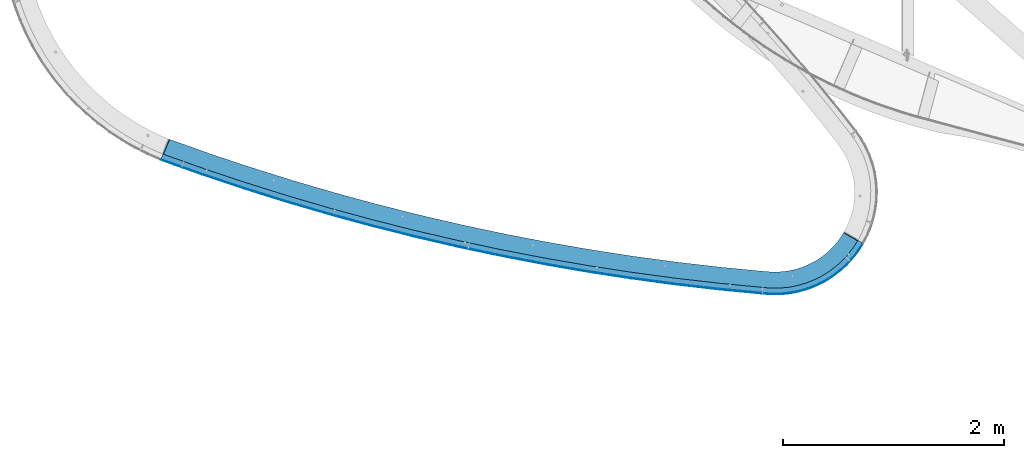
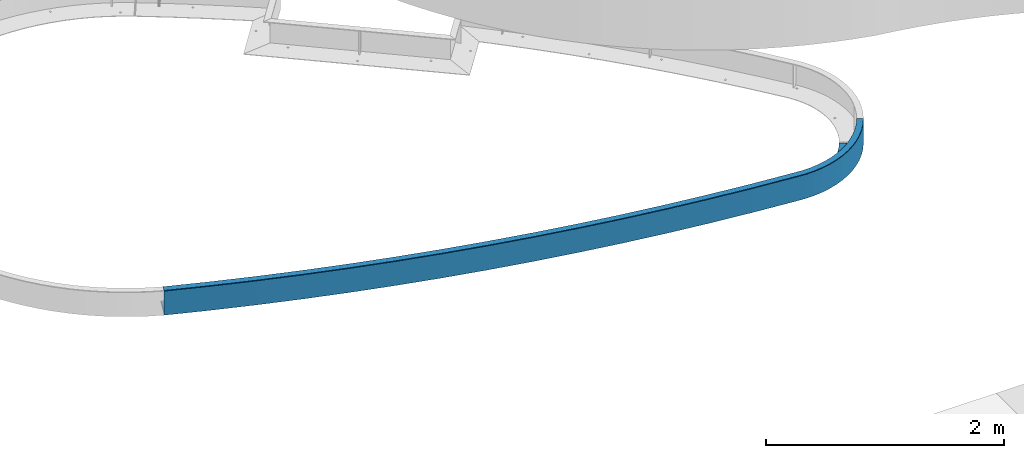
# One storey, part 1137 of 1763: 3 beams, 1 element without a shape of its own.
"""IFC2X3 building model written with IfcOpenShell, lengths in millimetres."""

from ifc_helpers import new_model, si_unit, frame, origin_with_axes, place, context, subcontext, project, spatial, faceted_brep, material, type_object, element, aggregate, save


model = new_model("IFC2X3")

# Units and contexts
model_context = context("Model", 3, precision=1e-05, world=origin_with_axes())
body_context = subcontext(model_context, "Body", "Model", "MODEL_VIEW")
ifc_project = project(units=[si_unit("LENGTHUNIT", "METRE", prefix="MILLI"), si_unit("AREAUNIT", "SQUARE_METRE"), si_unit("VOLUMEUNIT", "CUBIC_METRE"), si_unit("MASSUNIT", "GRAM", prefix="KILO"), si_unit("TIMEUNIT", "SECOND"), si_unit("PLANEANGLEUNIT", "RADIAN"), si_unit("SOLIDANGLEUNIT", "STERADIAN"), si_unit("THERMODYNAMICTEMPERATUREUNIT", "DEGREE_CELSIUS"), si_unit("LUMINOUSINTENSITYUNIT", "LUMEN")], contexts=[model_context])

# Site, building, storey
site_placement = place(None, origin_with_axes())
site = spatial("IfcSite", under=ifc_project, at=site_placement, CompositionType="ELEMENT")
building_placement = place(site_placement, origin_with_axes())
building = spatial("IfcBuilding", under=site, at=building_placement, Name="Undefined", CompositionType="ELEMENT")
storey_placement = place(building_placement, origin_with_axes())
storey = spatial("IfcBuildingStorey", under=building, at=storey_placement, Name="Undefined", CompositionType="ELEMENT", Elevation=0.0)

# Assembly, beams
assembly_placement = place(storey_placement, origin_with_axes())
assembly = element("IfcElementAssembly", 1, at=assembly_placement, inside=storey, Name="PLATE", AssemblyPlace="NOTDEFINED", PredefinedType="RIGID_FRAME")
ifc_material = material(Name="STEEL/A36")
beam_type_1 = type_object("IfcBeamType", PredefinedType="NOTDEFINED")
beam_1_placement = place(assembly_placement, frame((-53076.8570510666, 58481.2077564262, -250.825), z_axis=(0.27606807308732, 0.961138085304008, 0.0), x_axis=(0.961138085304008, -0.276068073087321, 0.0)))
beam_1 = element("IfcBeam", 2, at=beam_1_placement, type_object=beam_type_1, material=ifc_material, Name="PLATE", context=body_context, shape_type="Brep", body=[
    faceted_brep([(6318.82231450954, -1.11174358607968e-07, 927.30162043187), (6127.52354438154, -9.04748560515145e-08, 974.563433684867), (6125.72221636436, -3.17500000000001, 968.467541585356), (6317.02098650363, -3.17500000000001, 921.205728348854), (6094.23574031491, 3.17500000000001, 875.030074772294), (6094.23574031491, -3.17500000000001, 875.030074772294), (6112.92813320937, -3.17500000000001, 925.170957242546), (6112.92813320937, 3.17500000000001, 925.170957242546), (6072.11168569588, 3.17500000000001, 826.322101653786), (6072.11168569588, -3.17500000000001, 826.322101653786), (6046.65377505225, 3.17500000000001, 779.262257808557), (6046.65377505225, -3.17500000000001, 779.262257808557), (6018.67771271574, 3.17500000000001, 735.170138887748), (6018.67771271574, -3.17500000000001, 735.170138887748), (5987.58342440233, 3.17500000000001, 694.117283486135), (5987.58342440233, -3.17500000000001, 694.117283486135), (5952.56895111006, 3.17500000000001, 654.606839056389), (5952.56895111006, -3.17500000000001, 654.606839056389), (5914.38961194663, 3.17500000000001, 617.128491528601), (5914.38961194663, -3.17500000000001, 617.128491528601), (5873.69960085145, 3.17500000000001, 582.393143930181), (5873.69960085145, -3.17500000000001, 582.393143930181), (5831.14920615496, 3.17500000000001, 550.904240759119), (5831.14920615496, -3.17500000000001, 550.904240759119), (5787.56044065311, 3.17500000000001, 523.476084588234), (5787.56044065311, -3.17500000000001, 523.476084588234), (5741.30508837246, 3.17500000000001, 499.550699930085), (5741.30508837246, -3.17500000000001, 499.550699930085), (5692.1878851678, 3.17500000000001, 478.329351628185), (5692.1878851678, -3.17500000000001, 478.329351628185), (5641.72279028408, 3.17500000000001, 460.573819615332), (5641.72279028408, -3.17500000000001, 460.573819615332), (5590.06474646219, 3.17500000000001, 446.344274861054), (5590.06474646219, -3.17500000000001, 446.344274861054), (5532.32007577916, 3.17500000000001, 434.638579659295), (5532.32007577916, -3.17500000000001, 434.638579659295), (5531.83051360548, 3.17500000000001, 434.536833708546), (5531.83051360548, -3.17500000000001, 434.536833708546), (5142.47181492758, -3.17500000000001, 362.271568563781), (5142.47181492758, 3.17500000000001, 362.271568563781), (4751.81957522286, -3.17500000000001, 297.36168952928), (4751.81957522286, 3.17500000000001, 297.36168952928), (4360.01273256006, -3.17500000000001, 239.830282235482), (4360.01273256006, 3.17500000000001, 239.830282235482), (3967.19063565018, -3.17500000000001, 189.697808110235), (3967.19063565018, 3.17500000000001, 189.697808110235), (3573.49299428613, -3.17500000000001, 146.982097101609), (3573.49299428613, 3.17500000000001, 146.982097101609), (3179.05982965402, -3.17500000000001, 111.698341336472), (3179.05982965402, 3.17500000000001, 111.698341336472), (2784.03142453372, -3.17500000000001, 83.8590897173781), (2784.03142453372, 3.17500000000001, 83.8590897173781), (2388.54827340636, -3.17500000000001, 63.4742434594227), (2388.54827340636, 3.17500000000001, 63.4742434594227), (1992.75103248647, -3.17500000000001, 50.5510525688296), (1992.75103248647, 3.17500000000001, 50.5510525688296), (1596.78046969674, -3.17500000000001, 45.0941132644512), (1596.78046969674, 3.17500000000001, 45.0941132644512), (1200.7774146029, -3.17500000000001, 47.1053663430575), (1200.7774146029, 3.17500000000001, 47.1053663430575), (804.882708326841, -3.17500000000001, 56.5840964891177), (804.882708326841, 3.17500000000001, 56.5840964891177), (409.237153455426, -3.17500000000001, 73.5269325291592), (409.237153455426, 3.17500000000001, 73.5269325291592), (20.5117208271404, 3.17500000000001, 97.5247064266587), (20.5117208271404, 5.42727889296657e-08, 97.5247064266587), (26.855421667904, -3.17499997547534, 97.1330811670996), (6276.29428328179, -3.17500000000001, 799.853851910615), (6276.29428328179, 3.17500000000001, 799.853851910615), (6299.76876525953, 3.17500000000001, 862.82231445791), (6299.76876525953, -3.17500000000001, 862.82231445791), (6248.50823135956, -3.17500000000001, 738.680513957494), (6248.50823135956, 3.17500000000001, 738.680513957494), (6216.53629747939, -3.17500000000001, 679.57926889103), (6216.53629747939, 3.17500000000001, 679.57926889103), (6180.52264163674, -3.17500000000001, 622.819372623933), (6180.52264163674, 3.17500000000001, 622.819372623933), (6139.92997826181, -3.17500000000001, 569.226097772218), (6139.92997826181, 3.17500000000001, 569.226097772218), (6095.35232776908, -3.17500000000001, 518.924533390506), (6095.35232776908, 3.17500000000001, 518.924533390506), (6047.40306693633, -3.17500000000001, 471.855644809155), (6047.40306693633, 3.17500000000001, 471.855644809155), (5996.30064932723, -3.17500000000001, 428.231664598963), (5996.30064932723, 3.17500000000001, 428.231664598963), (5942.27602248493, -3.17500000000001, 388.251395188352), (5942.27602248493, 3.17500000000001, 388.251395188352), (5885.37250905599, -3.17500000000001, 352.444956647829), (5885.37250905599, 3.17500000000001, 352.444956647829), (5825.66324080095, -3.17500000000001, 321.560591050751), (5825.66324080095, 3.17500000000001, 321.560591050751), (5763.97857865328, -3.17500000000001, 294.909405418992), (5763.97857865328, 3.17500000000001, 294.909405418992), (5700.59891293702, -3.17500000000001, 272.610038179468), (5700.59891293702, 3.17500000000001, 272.610038179468), (5635.81159982171, -3.17500000000001, 254.76395065312), (5635.81159982171, 3.17500000000001, 254.76395065312), (5571.42900308751, -3.17500000000001, 241.712650078473), (5571.42900308751, 3.17500000000001, 241.712650078473), (5569.5759632992, -3.17500000000001, 241.339516110056), (5569.57596329931, 3.17500000000001, 241.339516110078), (5176.56723295026, 3.17500000000001, 168.396802362266), (5176.56723295026, -3.17500000000001, 168.396802362266), (4782.25283531217, 3.17500000000001, 102.878427575532), (4782.25283531217, -3.17500000000001, 102.878427575532), (4386.77301092455, 3.17500000000001, 44.807693795854), (4386.77301092455, -3.17500000000001, 44.807693795854), (3990.26841481875, 3.17500000000001, -5.79474573384505), (3990.26841481875, -3.17500000000001, -5.79474573384505), (3592.88006649304, 3.17500000000001, -48.910893919201), (3592.88006649304, -3.17500000000001, -48.910893919201), (3194.74929975803, 3.17500000000001, -84.5254162151759), (3194.74929975803, -3.17500000000001, -84.5254162151759), (2796.01771247038, 3.17500000000001, -112.625646079912), (2796.01771247038, -3.17500000000001, -112.625646079912), (2396.82711617259, 3.17500000000001, -133.201589479671), (2396.82711617259, -3.17500000000001, -133.201589479671), (1997.31948565675, 3.17500000000001, -146.245928443233), (1997.31948565675, -3.17500000000001, -146.245928443233), (1597.63690847029, 3.17500000000001, -151.754023664646), (1597.63690847029, -3.17500000000001, -151.754023664646), (1197.92153438159, 3.17500000000001, -149.723916153212), (1197.92153438159, -3.17500000000001, -149.723916153212), (798.315524823454, 3.17500000000001, -140.156327930134), (798.315524823454, -3.17500000000001, -140.156327930134), (398.961002332493, 3.17500000000001, -123.054661771865), (398.961002332493, -3.17500000000001, -123.054661771865), (5.59484760742635e-08, 3.17500000000001, -98.4250000019238), (6.34370078513166, -3.17500000000001, -98.8166252557639), (5.59484760742635e-08, 2.91902608751116e-08, -98.4250000019238), (6127.52354438154, 3.17500000000001, 974.563433684867), (6318.82231447691, 3.17500000000001, 927.301620299797)], [[[0, 1, 2, 3]], [[4, 5, 6, 7]], [[8, 9, 5, 4]], [[10, 11, 9, 8]], [[12, 13, 11, 10]], [[14, 15, 13, 12]], [[16, 17, 15, 14]], [[18, 19, 17, 16]], [[20, 21, 19, 18]], [[22, 23, 21, 20]], [[24, 25, 23, 22]], [[26, 27, 25, 24]], [[28, 29, 27, 26]], [[30, 31, 29, 28]], [[32, 33, 31, 30]], [[34, 35, 33, 32]], [[36, 37, 35, 34]], [[38, 37, 36, 39]], [[40, 38, 39, 41]], [[42, 40, 41, 43]], [[44, 42, 43, 45]], [[46, 44, 45, 47]], [[48, 46, 47, 49]], [[50, 48, 49, 51]], [[52, 50, 51, 53]], [[54, 52, 53, 55]], [[56, 54, 55, 57]], [[58, 56, 57, 59]], [[60, 58, 59, 61]], [[62, 60, 61, 63]], [[62, 63, 64, 65, 66]], [[67, 68, 69, 70]], [[71, 72, 68, 67]], [[73, 74, 72, 71]], [[75, 76, 74, 73]], [[77, 78, 76, 75]], [[79, 80, 78, 77]], [[81, 82, 80, 79]], [[83, 84, 82, 81]], [[85, 86, 84, 83]], [[87, 88, 86, 85]], [[89, 90, 88, 87]], [[91, 92, 90, 89]], [[93, 94, 92, 91]], [[95, 96, 94, 93]], [[97, 98, 96, 95]], [[99, 100, 98, 97]], [[101, 100, 99, 102]], [[103, 101, 102, 104]], [[105, 103, 104, 106]], [[107, 105, 106, 108]], [[109, 107, 108, 110]], [[111, 109, 110, 112]], [[113, 111, 112, 114]], [[115, 113, 114, 116]], [[117, 115, 116, 118]], [[119, 117, 118, 120]], [[121, 119, 120, 122]], [[123, 121, 122, 124]], [[125, 123, 124, 126]], [[127, 125, 126, 128, 129]], [[66, 65, 129, 128]], [[64, 127, 129, 65]], [[63, 61, 59, 57, 55, 53, 51, 49, 47, 45, 43, 41, 39, 36, 34, 32, 30, 28, 26, 24, 22, 20, 18, 16, 14, 12, 10, 8, 4, 7, 130, 131, 69, 68, 72, 74, 76, 78, 80, 82, 84, 86, 88, 90, 92, 94, 96, 98, 100, 101, 103, 105, 107, 109, 111, 113, 115, 117, 119, 121, 123, 125, 127, 64]], [[70, 69, 131, 0, 3]], [[6, 5, 9, 11, 13, 15, 17, 19, 21, 23, 25, 27, 29, 31, 33, 35, 37, 38, 40, 42, 44, 46, 48, 50, 52, 54, 56, 58, 60, 62, 66, 128, 126, 124, 122, 120, 118, 116, 114, 112, 110, 108, 106, 104, 102, 99, 97, 95, 93, 91, 89, 87, 85, 83, 81, 79, 77, 75, 73, 71, 67, 70, 3, 2]], [[130, 7, 6, 2, 1]], [[131, 130, 1, 0]]]),
])
beam_type_2 = type_object("IfcBeamType", PredefinedType="NOTDEFINED")
beam_2_placement = place(assembly_placement, frame((-46744.2698418956, 57627.1933740728, -130.175), z_axis=(0.0, 0.0, 1.0), x_axis=(-0.728032501654395, -0.685542614674568, 0.0)))
beam_2 = element("IfcBeam", 3, at=beam_2_placement, type_object=beam_type_2, material=ifc_material, Name="PLATE", context=body_context, shape_type="Brep", body=[
    faceted_brep([(7.99235992491413, -1.3421208866057, 123.825), (0.918660438013831, 0.135807899350766, 123.825), (0.918660438013831, 0.135807899350766, -123.825), (7.99234691937272, -1.34206961603195, -123.825), (-9.89530235528946e-10, 3.17499999998108, -123.825), (-9.89530235528946e-10, 3.17499999998108, 123.825), (80.6977583252865, 23.6451929419563, 123.825), (80.6977583252865, 23.6451929419563, -123.825), (162.911739607442, 36.760766880092, 123.825), (162.911739607442, 36.760766880092, -123.825), (245.973081028895, 42.415018312342, 123.825), (245.973081028895, 42.415018312342, -123.825), (329.20602596169, 40.561946321599, 123.825), (329.20602596169, 40.561946321599, -123.825), (411.933421674634, 31.2166268223373, 123.825), (411.933421674634, 31.2166268223373, -123.825), (493.48222839966, 14.4550899085298, 123.825), (493.48222839966, 14.4550899085298, -123.825), (573.188994936701, -9.58629869940341, 123.825), (573.188994936701, -9.58629869940341, -123.825), (650.405256249474, -40.7119470760517, 123.825), (650.405256249474, -40.7119470760517, -123.825), (724.502809139316, -78.6686283551971, 123.825), (724.502809139316, -78.6686283551971, -123.825), (794.878823076118, -123.147540890859, 123.825), (794.878823076118, -123.147540890859, -123.825), (860.960744606591, -173.786820554262, 123.825), (860.960744606591, -173.786820554262, -123.825), (922.210955439294, -230.17448472773, 123.825), (922.210955439294, -230.17448472773, -123.825), (978.131146309939, -291.851784044236, 123.825), (978.131146309939, -291.851784044236, -123.825), (978.777592559496, -292.632858783894, 123.825), (978.777592559496, -292.632858783894, -123.825), (979.434201557646, -293.368561150884, 123.825), (979.434201557646, -293.368561150884, -123.825), (1242.81164874635, -594.132378442766, 123.825), (1242.81164874635, -594.132378442766, -123.825), (1500.47124140349, -899.808821420273, 123.825), (1500.47124140349, -899.808821420273, -123.825), (1752.32136637089, -1210.28920410736, 123.825), (1752.32136637089, -1210.28920410736, -123.825), (1998.27247609828, -1525.46313244454, 123.825), (1998.27247609828, -1525.46313244454, -123.825), (2238.23712048266, -1845.21854354042, 123.825), (2238.23712048266, -1845.21854354042, -123.825), (2472.12997796201, -2169.44174551673, 123.825), (2472.12997796201, -2169.44174551673, -123.825), (2699.86788585211, -2498.01745793241, 123.825), (2699.86788585211, -2498.01745793241, -123.825), (2921.36986991572, -2830.82885277265, 123.825), (2921.36986991572, -2830.82885277265, -123.825), (3136.55717315379, -3167.75759598808, 123.825), (3136.55717315379, -3167.75759598808, -123.825), (3345.35328380816, -3508.6838895696, 123.825), (3345.35328380816, -3508.6838895696, -123.825), (3547.68396256597, -3853.48651414347, 123.825), (3547.68396256597, -3853.48651414347, -123.825), (3743.47726895613, -4202.04287207202, 123.825), (3743.47726895613, -4202.04287207202, -123.825), (3932.66358692843, -4554.22903104439, 123.825), (3932.66358692843, -4554.22903104439, -123.825), (4115.17564960615, -4909.9197681417, 123.825), (4115.17564960615, -4909.9197681417, -123.825), (4112.3238753683, -4911.31593058459, 123.825), (4112.33723008117, -4911.34257253062, -123.825), (4106.60006284934, -4907.11586190463, 123.825), (4106.60006284934, -4907.11586190463, -123.825), (3927.04151622048, -4557.18111860318, 123.825), (3927.04151622048, -4557.18111860318, -123.825), (3737.91186062035, -4205.10044137725, -123.825), (3737.91186062035, -4205.10044137725, 123.825), (3542.17719543277, -3856.64847804914, -123.825), (3542.17719543277, -3856.64847804914, 123.825), (3339.90711585753, -3511.94912381138, -123.825), (3339.90711585753, -3511.94912381138, 123.825), (3131.17354081916, -3171.12493958292, -123.825), (3131.17354081916, -3171.12493958292, 123.825), (2916.0506873954, -2834.29710843158, -123.825), (2916.0506873954, -2834.29710843158, 123.825), (2694.61504442872, -2501.5853924863, -123.825), (2694.61504442872, -2501.5853924863, 123.825), (2466.94534533004, -2173.10809035478, -123.825), (2466.94534533004, -2173.10809035478, 123.825), (2233.12254008428, -1848.98199506113, -123.825), (2233.12254008428, -1848.98199506113, 123.825), (1993.22976646801, -1529.32235251924, -123.825), (1993.22976646801, -1529.32235251924, 123.825), (1747.35232048897, -1214.24282055609, -123.825), (1747.35232048897, -1214.24282055609, 123.825), (1495.57762605834, -903.855428499548, -123.825), (1495.57762605834, -903.855428499548, 123.825), (1237.99520390641, -598.270537345452, -123.825), (1237.99520390641, -598.270537345452, 123.825), (974.696639752668, -297.596800517829, 123.825), (974.696639752668, -297.596800517829, -123.825), (973.961196847746, -296.772768121911, 123.825), (973.961196847746, -296.772768121911, -123.825), (973.239264095804, -295.900486108265, 123.825), (973.239264095804, -295.900486108265, -123.825), (917.703784743198, -234.647505219124, -123.825), (917.703784743198, -234.647505219124, 123.825), (856.874954117242, -178.647768617884, -123.825), (856.874954117242, -178.647768617884, 123.825), (791.247653287281, -128.356869635027, -123.825), (791.247653287281, -128.356869635027, 123.825), (721.355801917407, -84.1839565906994, -123.825), (721.355801917407, -84.1839565906994, 123.825), (647.768014491738, -46.4884041140031, -123.825), (647.768014491738, -46.4884041140031, 123.825), (571.08297427539, -15.5768894026842, -123.825), (571.08297427539, -15.5768894026842, 123.825), (491.924562646918, 8.29910279004253, -123.825), (491.924562646918, 8.29910279004253, 123.825), (410.936783428077, 24.9453261434101, -123.825), (410.936783428077, 24.9453261434101, 123.825), (328.778523504776, 34.2263530858036, -123.825), (328.778523504776, 34.2263530858036, 123.825), (246.118192364911, 36.066676583956, -123.825), (246.118192364911, 36.066676583956, 123.825), (163.628284163757, 30.4513244404516, -123.825), (163.628284163757, 30.4513244404516, 123.825), (81.9799065580428, 17.4259811020602, -123.825), (81.9799065580428, 17.4259811020602, 123.825)], [[[0, 1, 2, 3]], [[4, 5, 6, 7]], [[6, 8, 9, 7]], [[8, 10, 11, 9]], [[10, 12, 13, 11]], [[12, 14, 15, 13]], [[14, 16, 17, 15]], [[16, 18, 19, 17]], [[18, 20, 21, 19]], [[20, 22, 23, 21]], [[22, 24, 25, 23]], [[24, 26, 27, 25]], [[26, 28, 29, 27]], [[28, 30, 31, 29]], [[31, 30, 32, 33]], [[33, 32, 34, 35]], [[35, 34, 36, 37]], [[36, 38, 39, 37]], [[38, 40, 41, 39]], [[40, 42, 43, 41]], [[42, 44, 45, 43]], [[44, 46, 47, 45]], [[46, 48, 49, 47]], [[48, 50, 51, 49]], [[50, 52, 53, 51]], [[52, 54, 55, 53]], [[54, 56, 57, 55]], [[56, 58, 59, 57]], [[58, 60, 61, 59]], [[60, 62, 63, 61]], [[63, 62, 64, 65]], [[64, 66, 67, 65]], [[68, 69, 67, 66]], [[70, 69, 68, 71]], [[72, 70, 71, 73]], [[74, 72, 73, 75]], [[76, 74, 75, 77]], [[78, 76, 77, 79]], [[80, 78, 79, 81]], [[82, 80, 81, 83]], [[84, 82, 83, 85]], [[86, 84, 85, 87]], [[88, 86, 87, 89]], [[90, 88, 89, 91]], [[92, 90, 91, 93]], [[94, 95, 92, 93]], [[96, 97, 95, 94]], [[98, 99, 97, 96]], [[100, 99, 98, 101]], [[102, 100, 101, 103]], [[104, 102, 103, 105]], [[106, 104, 105, 107]], [[108, 106, 107, 109]], [[110, 108, 109, 111]], [[112, 110, 111, 113]], [[114, 112, 113, 115]], [[116, 114, 115, 117]], [[118, 116, 117, 119]], [[120, 118, 119, 121]], [[122, 120, 121, 123]], [[122, 123, 0, 3]], [[4, 7, 9, 11, 13, 15, 17, 19, 21, 23, 25, 27, 29, 31, 33, 35, 37, 39, 41, 43, 45, 47, 49, 51, 53, 55, 57, 59, 61, 63, 65, 67, 69, 70, 72, 74, 76, 78, 80, 82, 84, 86, 88, 90, 92, 95, 97, 99, 100, 102, 104, 106, 108, 110, 112, 114, 116, 118, 120, 122, 3, 2]], [[5, 4, 2, 1]], [[123, 121, 119, 117, 115, 113, 111, 109, 107, 105, 103, 101, 98, 96, 94, 93, 91, 89, 87, 85, 83, 81, 79, 77, 75, 73, 71, 68, 66, 64, 62, 60, 58, 56, 54, 52, 50, 48, 46, 44, 42, 40, 38, 36, 34, 32, 30, 28, 26, 24, 22, 20, 18, 16, 14, 12, 10, 8, 6, 5, 1, 0]]]),
])
beam_type_3 = type_object("IfcBeamType", PredefinedType="NOTDEFINED")
beam_3_placement = place(assembly_placement, frame((-46761.6823899913, 57645.6854091817, -3.17499999999491), z_axis=(0.685542614674568, -0.728032501654395, 0.0), x_axis=(-0.728032501654395, -0.685542614674568, 0.0)))
beam_3 = element("IfcBeam", 4, at=beam_3_placement, type_object=beam_type_3, material=ifc_material, Name="PLATE", context=body_context, shape_type="Brep", body=[
    faceted_brep([(22.690981146161, 3.17500000464634, -24.5689123684278), (16.5358801446364, 9.96558560117933e-08, -26.1304583013844), (-8.84756445884705e-09, 9.69761293490023e-09, 28.5749999999134), (6.15508562162904, 3.175, 30.1365420300572), (80.6389212364975, -3.175, 49.0330525091995), (162.792356629785, -3.175, 62.1471892756817), (162.792356629785, 3.175, 62.1471892756817), (80.6389212364975, 3.175, 49.0330525091995), (245.792900142887, -3.175, 67.810872404094), (245.792900142887, 3.175, 67.810872404094), (328.966263915996, -3.175, 65.9780907165405), (328.966263915996, 3.175, 65.9780907165405), (411.636756115355, -3.175, 56.6637335424894), (411.636756115355, 3.175, 56.6637335424894), (493.132770184007, -3.175, 39.9434697595425), (493.132770184007, 3.175, 39.9434697595425), (572.792240904275, -3.175, 15.9531330671016), (572.792240904275, 3.175, 15.9531330671016), (649.968022947332, -3.175, -15.1123815124447), (649.968022947332, 3.175, -15.1123815124447), (724.03314821514, -3.175, -53.0007009408873), (724.03314821514, 3.175, -53.0007009408873), (794.385919264672, -3.175, -97.4040244167263), (794.385919264672, 3.175, -97.4040244167263), (860.454797435903, -3.175, -147.961623917159), (860.454797435903, 3.175, -147.961623917159), (921.703045972938, -3.175, -204.262774715287), (921.703045972938, 3.175, -204.262774715287), (977.63309041814, -3.175, -265.850092065593), (977.63309041814, 3.175, -265.850092065593), (978.280399047517, -3.175, -266.630861772472), (978.280399047517, 3.175, -266.630861772472), (978.936813269424, -3.175, -267.3663157837), (978.936813269424, 3.175, -267.3663157837), (1242.35699351795, -3.175, -568.166885436833), (1242.35699351795, 3.175, -568.166885436833), (1500.05831639211, -3.175, -873.881134785333), (1500.05831639211, 3.175, -873.881134785333), (1751.94914428746, -3.175, -1184.40035301185), (1751.94914428746, 3.175, -1184.40035301185), (1997.93990578937, -3.175, -1499.61412067042), (1997.93990578937, 3.175, -1499.61412067042), (2237.94312752423, -3.175, -1819.41034895134), (2237.94312752423, 3.175, -1819.41034895134), (2471.87346526465, -3.175, -2143.67531953937), (2471.87346526465, 3.175, -2143.67531953937), (2699.64773427759, -3.175, -2472.29372505163), (2699.64773427759, 3.175, -2472.29372505163), (2921.18493890447, -3.175, -2805.14871004048), (2921.18493890447, 3.175, -2805.14871004048), (3136.40630136292, -3.175, -3142.12191254675), (3136.40630136292, 3.175, -3142.12191254675), (3345.23528975993, -3.175, -3483.09350618892), (3345.23528975993, 3.175, -3483.09350618892), (3547.59764530622, -3.175, -3827.9422427729), (3547.59764530622, 3.175, -3827.9422427729), (3743.4214087224, -3.175, -4176.54549540736), (3743.4214087224, 3.175, -4176.54549540736), (3932.63694582744, -3.175, -4528.77930210947), (3932.63694582744, 3.175, -4528.77930210947), (4115.17697230037, -3.175, -4884.51840988529), (4115.17680408879, 4.01432575181104e-07, -4884.51804551187), (4112.37157467348, 3.175, -4879.05117254547), (169.248649110321, 3.175, 5.3630472341174), (247.110061576148, 3.175, 10.6760530226748), (247.110061576148, -3.175, 10.6760530226748), (169.248649110321, -3.175, 5.3630472341174), (325.133593818284, 3.175, 8.95675137842773), (325.133593818284, -3.175, 8.95675137842773), (402.685390703447, 3.175, 0.219109730722266), (402.685390703447, -3.175, 0.219109730722266), (479.135429427815, 3.175, -15.4658882203803), (479.135429427815, -3.175, -15.4658882203803), (553.862637757267, 3.175, -37.9708191683021), (553.862637757267, -3.175, -37.9708191683021), (626.259939554193, 3.175, -67.1128553738818), (626.259939554193, -3.175, -67.1128553738818), (695.73918660154, 3.175, -102.655249938922), (695.73918660154, -3.175, -102.655249938922), (761.735936658219, 3.175, -144.309260113689), (761.735936658219, -3.175, -144.309260113689), (823.714038929707, 3.175, -191.736493013246), (823.714038929707, -3.175, -191.736493013246), (881.169989701872, 3.175, -244.551654686278), (881.169989701872, -3.175, -244.551654686278), (933.637022753204, 3.175, -302.325680203576), (933.637022753204, -3.175, -302.325680203576), (934.949326651304, 3.175, -303.908552860201), (934.949326651304, -3.175, -303.908552860201), (936.299531176957, 3.175, -305.421337472799), (936.299531176965, -3.175, -305.421337472799), (1199.00971079419, 3.175, -605.411154532296), (1199.00971079419, -3.175, -605.411154532296), (1456.01644716491, 3.175, -910.301407367588), (1456.01644716491, -3.175, -910.301407367588), (1707.22834967704, 3.175, -1219.98367817129), (1707.22834967704, -3.175, -1219.98367817129), (1952.55608833918, 3.175, -1534.34784511279), (1952.55608833918, -3.175, -1534.34784511279), (2191.9124255461, 3.175, -1853.28212149709), (2191.9124255461, -3.175, -1853.28212149709), (2425.21224710011, 3.175, -2176.67309551578), (2425.21224710011, -3.175, -2176.67309551578), (2652.37259247728, 3.175, -2504.40577057586), (2652.37259247728, -3.175, -2504.40577057586), (2873.31268432792, 3.175, -2836.36360619195), (2873.31268432792, -3.175, -2836.36360619195), (3087.95395720071, 3.175, -3172.42855942785), (3087.95395720071, -3.175, -3172.42855942785), (3296.22008548025, 3.175, -3512.48112687198), (3296.22008548025, -3.175, -3512.48112687198), (3498.03701052819, 3.175, -3856.40038713242), (3498.03701052819, -3.175, -3856.40038713242), (3693.33296701811, 3.175, -4204.06404383612), (3693.33296701811, -3.175, -4204.06404383612), (3882.03850845513, 3.175, -4555.3484691169), (3882.03850845513, -3.175, -4555.3484691169), (4063.24659941312, -3.175, -4908.49186371767), (4060.44120178261, 3.175, -4903.0246263708), (4063.24659941312, 3.82777525675948e-07, -4908.49186371767), (-8.84756445884705e-09, -3.175, 28.5749999999134), (16.5358801446364, -3.175, -26.1304583013844), (92.1818945097057, -3.175, -6.93910367586068), (92.1818945097057, 3.175, -6.93910367586068)], [[[0, 1, 2, 3]], [[4, 5, 6, 7]], [[5, 8, 9, 6]], [[8, 10, 11, 9]], [[10, 12, 13, 11]], [[12, 14, 15, 13]], [[14, 16, 17, 15]], [[16, 18, 19, 17]], [[18, 20, 21, 19]], [[20, 22, 23, 21]], [[22, 24, 25, 23]], [[24, 26, 27, 25]], [[26, 28, 29, 27]], [[29, 28, 30, 31]], [[31, 30, 32, 33]], [[33, 32, 34, 35]], [[34, 36, 37, 35]], [[36, 38, 39, 37]], [[38, 40, 41, 39]], [[40, 42, 43, 41]], [[42, 44, 45, 43]], [[44, 46, 47, 45]], [[46, 48, 49, 47]], [[48, 50, 51, 49]], [[50, 52, 53, 51]], [[52, 54, 55, 53]], [[54, 56, 57, 55]], [[56, 58, 59, 57]], [[59, 58, 60, 61, 62]], [[63, 64, 65, 66]], [[64, 67, 68, 65]], [[67, 69, 70, 68]], [[69, 71, 72, 70]], [[71, 73, 74, 72]], [[73, 75, 76, 74]], [[75, 77, 78, 76]], [[77, 79, 80, 78]], [[79, 81, 82, 80]], [[81, 83, 84, 82]], [[83, 85, 86, 84]], [[86, 85, 87, 88]], [[88, 87, 89, 90]], [[90, 89, 91, 92]], [[91, 93, 94, 92]], [[93, 95, 96, 94]], [[95, 97, 98, 96]], [[97, 99, 100, 98]], [[99, 101, 102, 100]], [[101, 103, 104, 102]], [[103, 105, 106, 104]], [[105, 107, 108, 106]], [[107, 109, 110, 108]], [[109, 111, 112, 110]], [[111, 113, 114, 112]], [[113, 115, 116, 114]], [[117, 116, 115, 118, 119]], [[61, 119, 118, 62]], [[60, 117, 119, 61]], [[58, 56, 54, 52, 50, 48, 46, 44, 42, 40, 38, 36, 34, 32, 30, 28, 26, 24, 22, 20, 18, 16, 14, 12, 10, 8, 5, 4, 120, 121, 122, 66, 65, 68, 70, 72, 74, 76, 78, 80, 82, 84, 86, 88, 90, 92, 94, 96, 98, 100, 102, 104, 106, 108, 110, 112, 114, 116, 117, 60]], [[123, 63, 66, 122]], [[7, 6, 9, 11, 13, 15, 17, 19, 21, 23, 25, 27, 29, 31, 33, 35, 37, 39, 41, 43, 45, 47, 49, 51, 53, 55, 57, 59, 62, 118, 115, 113, 111, 109, 107, 105, 103, 101, 99, 97, 95, 93, 91, 89, 87, 85, 83, 81, 79, 77, 75, 73, 71, 69, 67, 64, 63, 123, 0, 3]], [[120, 4, 7, 3, 2]], [[121, 120, 2, 1]], [[123, 122, 121, 1, 0]]]),
])
aggregate(assembly, [beam_3, beam_2, beam_1])

save(model, "model.ifc")
